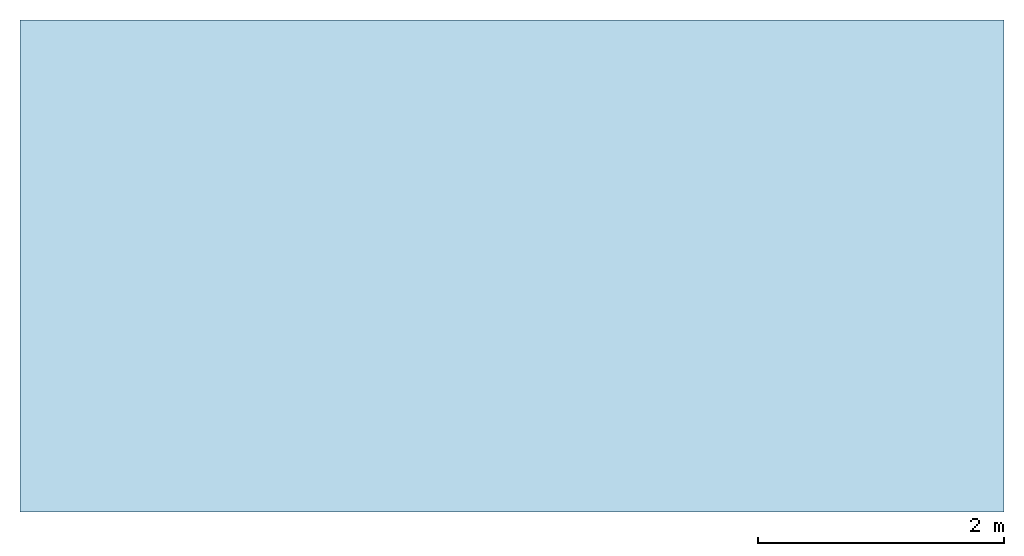
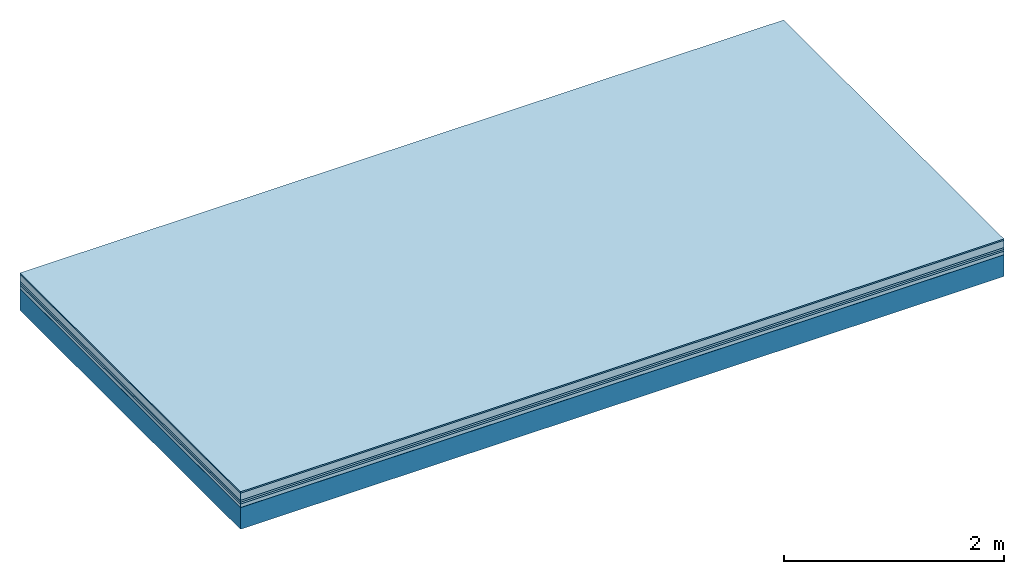
# One storey: 6 plates, 1 member, 1 element without a shape of its own.
"""IFC4 building model written with IfcOpenShell, lengths in metres."""

from ifc_helpers import new_model, si_unit, derived_unit, direction, frame, frame_2d, origin, origin_with_axes, place, context, project, spatial, rectangle, extrude, material, layer, layer_set, type_object, element, aggregate, save


model = new_model("IFC4")

# Units and contexts
plan_context = context("Plan", 3, precision=1e-05, world=origin(), true_north=direction((0.0, 1.0)))
model_context = context("Model", 3, precision=1e-05, world=origin(), true_north=direction((0.0, 1.0)))
ifc_project = project(units=[si_unit("LENGTHUNIT", "METRE"), derived_unit("SOUNDPRESSUREUNIT", [(si_unit("PRESSUREUNIT", "PASCAL", prefix="MICRO"), 0)]), si_unit("ENERGYUNIT", "JOULE", prefix="MEGA"), si_unit("MASSUNIT", "GRAM", prefix="KILO"), derived_unit("THERMALTRANSMITTANCEUNIT", [(si_unit("POWERUNIT", "WATT"), 1), (si_unit("AREAUNIT", "SQUARE_METRE"), -1), (si_unit("THERMODYNAMICTEMPERATUREUNIT", "KELVIN"), -1)]), derived_unit("AREADENSITYUNIT", [(si_unit("MASSUNIT", "GRAM", prefix="KILO"), 1), (si_unit("AREAUNIT", "SQUARE_METRE"), -1)]), derived_unit("USERDEFINED", [(si_unit("ENERGYUNIT", "JOULE", prefix="MEGA"), 1), (si_unit("AREAUNIT", "SQUARE_METRE"), -1)])], contexts=[plan_context, model_context])

# Site, building, storey
site = spatial("IfcSite", under=ifc_project)
building_placement = place(None, origin())
building = spatial("IfcBuilding", under=site, at=building_placement)
storey_placement = place(building_placement, origin())
storey = spatial("IfcBuildingStorey", under=building, at=storey_placement)

# Slab, member, plates
ifc_material_1 = material(Category="11.013")
ifc_layer_1 = layer(ifc_material_1, 0.015, Name="Flooring")
ifc_material_2 = material(Name="Cement screed", Category="04.006")
ifc_layer_2 = layer(ifc_material_2, 0.08, Name="On-material")
ifc_material_3 = material(Name="Wood fiber generic product", Category="10.009")
ifc_layer_3 = layer(ifc_material_3, 0.02, Name="Impact sound insulation")
ifc_material_4 = material()
ifc_layer_4 = layer(ifc_material_4, 0.02, Name="Additional insulation")
ifc_material_5 = material(Name="Cement panels, glued on sub-floor", Category="02.007")
ifc_layer_5 = layer(ifc_material_5, 0.04, Name="on Supporting structure")
ifc_material_6 = material(Name="protection", Category="09.007")
ifc_layer_6 = layer(ifc_material_6, 0.0005, Name="Sub-floor")
ifc_material_7 = material(Name="no composite action")
ifc_layer_7 = layer(ifc_material_7, 0.0, Name="Bond")
ifc_layer_8 = layer(None, 0.24, Name="Supporting structure")
ifc_layer_set = layer_set([ifc_layer_1, ifc_layer_2, ifc_layer_3, ifc_layer_4, ifc_layer_5, ifc_layer_6, ifc_layer_7, ifc_layer_8])
slab_type = type_object("IfcSlabType", Name="A2093", PredefinedType="NOTDEFINED", material=ifc_layer_set)
slab_placement = place(None, frame((0.0, 0.0, 0.0), z_axis=(0.0, 0.0, -1.0), x_axis=(1.0, 0.0, 0.0)))
slab = element("IfcSlab", 1, at=slab_placement, inside=storey, type_object=slab_type, material=ifc_layer_set, Name="Slab #1")
ifc_material_8 = material(Name="Solid timber panel")
member_placement = place(slab_placement, origin())
member = element("IfcMember", 2, at=member_placement, material=ifc_material_8, Name="Supporting structure", context=plan_context, shape_type="SweptSolid", body=[
    extrude(rectangle(XDim=1.0, YDim=0.24, at=frame_2d((0.5, 0.12), x_axis=(1.0, 0.0))), frame((0.0, 4.0, 0.1755), z_axis=(0.0, -1.0, 0.0), x_axis=(1.0, 0.0, 0.0)), (0.0, 0.0, 1.0), 4.0),
    extrude(rectangle(XDim=1.0, YDim=0.24, at=frame_2d((0.5, 0.12), x_axis=(1.0, 0.0))), frame((1.0, 4.0, 0.1755), z_axis=(0.0, -1.0, 0.0), x_axis=(1.0, 0.0, 0.0)), (0.0, 0.0, 1.0), 4.0),
    extrude(rectangle(XDim=1.0, YDim=0.24, at=frame_2d((0.5, 0.12), x_axis=(1.0, 0.0))), frame((2.0, 4.0, 0.1755), z_axis=(0.0, -1.0, 0.0), x_axis=(1.0, 0.0, 0.0)), (0.0, 0.0, 1.0), 4.0),
    extrude(rectangle(XDim=1.0, YDim=0.24, at=frame_2d((0.5, 0.12), x_axis=(1.0, 0.0))), frame((3.0, 4.0, 0.1755), z_axis=(0.0, -1.0, 0.0), x_axis=(1.0, 0.0, 0.0)), (0.0, 0.0, 1.0), 4.0),
    extrude(rectangle(XDim=1.0, YDim=0.24, at=frame_2d((0.5, 0.12), x_axis=(1.0, 0.0))), frame((4.0, 4.0, 0.1755), z_axis=(0.0, -1.0, 0.0), x_axis=(1.0, 0.0, 0.0)), (0.0, 0.0, 1.0), 4.0),
    extrude(rectangle(XDim=1.0, YDim=0.24, at=frame_2d((0.5, 0.12), x_axis=(1.0, 0.0))), frame((5.0, 4.0, 0.1755), z_axis=(0.0, -1.0, 0.0), x_axis=(1.0, 0.0, 0.0)), (0.0, 0.0, 1.0), 4.0),
    extrude(rectangle(XDim=1.0, YDim=0.24, at=frame_2d((0.5, 0.12), x_axis=(1.0, 0.0))), frame((6.0, 4.0, 0.1755), z_axis=(0.0, -1.0, 0.0), x_axis=(1.0, 0.0, 0.0)), (0.0, 0.0, 1.0), 4.0),
    extrude(rectangle(XDim=1.0, YDim=0.24, at=frame_2d((0.5, 0.12), x_axis=(1.0, 0.0))), frame((7.0, 4.0, 0.1755), z_axis=(0.0, -1.0, 0.0), x_axis=(1.0, 0.0, 0.0)), (0.0, 0.0, 1.0), 4.0),
])
plate_1_placement = place(slab_placement, origin())
plate_1 = element("IfcPlate", 3, at=plate_1_placement, material=ifc_material_1, Name="Flooring", context=plan_context, shape_type="SweptSolid", body=[
    extrude(rectangle(XDim=8.0, YDim=4.0, at=frame_2d((4.0, 2.0), x_axis=(1.0, 0.0))), origin_with_axes(), (0.0, 0.0, 1.0), 0.015),
])
plate_2_placement = place(slab_placement, origin())
plate_2 = element("IfcPlate", 4, at=plate_2_placement, material=ifc_material_2, Name="On-material", context=plan_context, shape_type="SweptSolid", body=[
    extrude(rectangle(XDim=8.0, YDim=4.0, at=frame_2d((4.0, 2.0), x_axis=(1.0, 0.0))), frame((0.0, 0.0, 0.015), z_axis=(0.0, 0.0, 1.0), x_axis=(1.0, 0.0, 0.0)), (0.0, 0.0, 1.0), 0.08),
])
plate_3_placement = place(slab_placement, origin())
plate_3 = element("IfcPlate", 5, at=plate_3_placement, material=ifc_material_3, Name="Impact sound insulation", context=plan_context, shape_type="SweptSolid", body=[
    extrude(rectangle(XDim=8.0, YDim=4.0, at=frame_2d((4.0, 2.0), x_axis=(1.0, 0.0))), frame((0.0, 0.0, 0.095), z_axis=(0.0, 0.0, 1.0), x_axis=(1.0, 0.0, 0.0)), (0.0, 0.0, 1.0), 0.02),
])
plate_4_placement = place(slab_placement, origin())
plate_4 = element("IfcPlate", 6, at=plate_4_placement, material=ifc_material_4, Name="Additional insulation", context=plan_context, shape_type="SweptSolid", body=[
    extrude(rectangle(XDim=8.0, YDim=4.0, at=frame_2d((4.0, 2.0), x_axis=(1.0, 0.0))), frame((0.0, 0.0, 0.115), z_axis=(0.0, 0.0, 1.0), x_axis=(1.0, 0.0, 0.0)), (0.0, 0.0, 1.0), 0.02),
])
plate_5_placement = place(slab_placement, origin())
plate_5 = element("IfcPlate", 7, at=plate_5_placement, material=ifc_material_5, Name="on Supporting structure", context=plan_context, shape_type="SweptSolid", body=[
    extrude(rectangle(XDim=8.0, YDim=4.0, at=frame_2d((4.0, 2.0), x_axis=(1.0, 0.0))), frame((0.0, 0.0, 0.135), z_axis=(0.0, 0.0, 1.0), x_axis=(1.0, 0.0, 0.0)), (0.0, 0.0, 1.0), 0.04),
])
plate_6_placement = place(slab_placement, origin())
plate_6 = element("IfcPlate", 8, at=plate_6_placement, material=ifc_material_6, Name="Sub-floor", context=plan_context, shape_type="SweptSolid", body=[
    extrude(rectangle(XDim=8.0, YDim=4.0, at=frame_2d((4.0, 2.0), x_axis=(1.0, 0.0))), frame((0.0, 0.0, 0.175), z_axis=(0.0, 0.0, 1.0), x_axis=(1.0, 0.0, 0.0)), (0.0, 0.0, 1.0), 0.0005),
])
aggregate(slab, [plate_1, plate_2, plate_3, plate_4, plate_5, plate_6, member])

save(model, "model.ifc")
